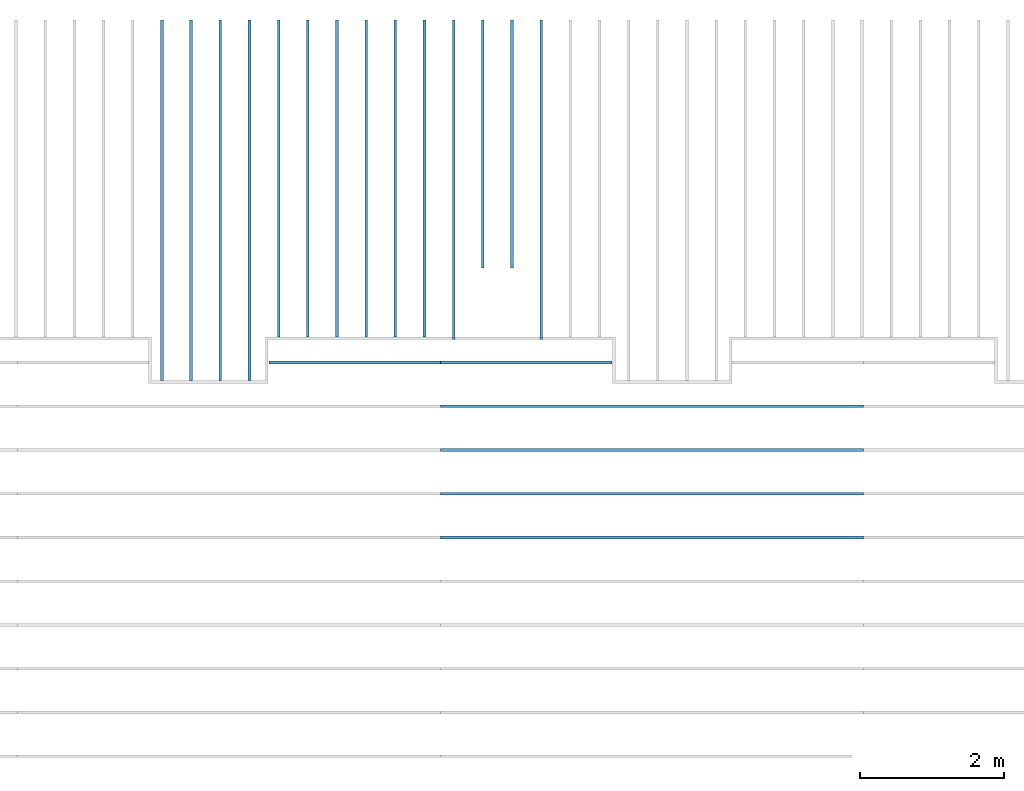
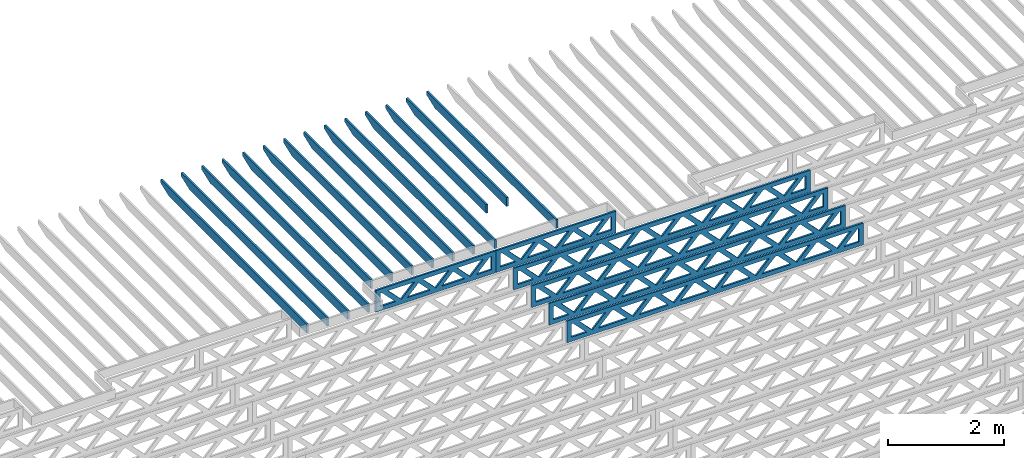
# One storey, part 9 of 18: 20 beams, 3 elements without a shape of their own.
"""IFC4 building model written with IfcOpenShell, lengths in feet."""

import ifcopenshell
import ifcopenshell.guid

model = None  # the IFC model being written
_history = None  # IfcOwnerHistory: only IFC2X3 demands one
_inside = {}  # id of a spatial element -> (the spatial element, [elements in it])
_under = {}  # id of a project, library or spatial element -> (it, [spatial elements below it])
_declared = {}  # id of a project -> (the project, [libraries it declares])
_typed = {}  # id of a type object -> (the type object, [elements of that type])
_made_of = {}  # id of a material, layer set ... -> (it, [elements and type objects made of it])


def new_model(schema):
    """Start an empty IFC model of exactly this schema.

    Asked for "IFC4X3", IfcOpenShell would pick the latest addendum, in which some entities
    have other attributes; the version numbers below select the first issue.
    IFC2X3 requires an IfcOwnerHistory on every rooted entity: one is made here for all.
    """
    global model, _history
    if schema == "IFC4X3":
        model = ifcopenshell.file(schema_version=(4, 3, 0, 0))
    else:
        model = ifcopenshell.file(schema=schema)
    _inside.clear()
    _under.clear()
    _declared.clear()
    _typed.clear()
    _made_of.clear()
    _history = None
    if model.schema == "IFC2X3":
        org = make("IfcOrganization", Name="unknown")
        user = make(
            "IfcPersonAndOrganization",
            ThePerson=make("IfcPerson", FamilyName="unknown"),
            TheOrganization=org,
        )
        app = make(
            "IfcApplication",
            ApplicationDeveloper=org,
            Version="unknown",
            ApplicationFullName="unknown",
            ApplicationIdentifier="unknown",
        )
        _history = make(
            "IfcOwnerHistory",
            OwningUser=user,
            OwningApplication=app,
            ChangeAction="ADDED",
            CreationDate=0,
        )
    return model


def make(cls, **values):
    """One entity of the class cls with the attributes given. An attribute that is None is left unset."""
    return model.create_entity(
        cls, **{name: value for name, value in values.items() if value is not None}
    )


def entity(cls, *values):
    """Any entity or typed value of the class cls, its attributes in the order of the schema. None: left unset."""
    e = model.create_entity(cls)
    for i, value in enumerate(values):
        if value is not None:
            e[i] = value
    return e


def rooted(cls, **values):
    """An entity with a GlobalId (a new one), such as an element, a storey or a relation."""
    return make(cls, GlobalId=ifcopenshell.guid.new(), OwnerHistory=_history, **values)


def si_unit(unit_type, name, prefix=None):
    """IfcSIUnit, for example si_unit("LENGTHUNIT", "METRE", prefix="MILLI")."""
    return make("IfcSIUnit", UnitType=unit_type, Prefix=prefix, Name=name)


def converted_unit(unit_type, name, factor, base, dimensions=None, offset=None):
    """IfcConversionBasedUnit, such as the inch: factor (a typed value) times the base unit."""
    return make(
        "IfcConversionBasedUnit"
        if offset is None
        else "IfcConversionBasedUnitWithOffset",
        ConversionOffset=offset,
        Dimensions=None
        if dimensions is None
        else entity("IfcDimensionalExponents", *dimensions),
        UnitType=unit_type,
        Name=name,
        ConversionFactor=make(
            "IfcMeasureWithUnit", ValueComponent=factor, UnitComponent=base
        ),
    )


def derived_unit(unit_type, elements):
    """IfcDerivedUnit: a product of units, each with its exponent."""
    return make(
        "IfcDerivedUnit",
        Elements=[
            make("IfcDerivedUnitElement", Unit=unit, Exponent=power)
            for unit, power in elements
        ],
        UnitType=unit_type,
    )


def assignment(units):
    """IfcUnitAssignment: the units of a project."""
    return None if units is None else make("IfcUnitAssignment", Units=units)


def point(xyz):
    """IfcCartesianPoint."""
    return None if xyz is None else make("IfcCartesianPoint", Coordinates=xyz)


def direction(xyz):
    """IfcDirection."""
    return None if xyz is None else make("IfcDirection", DirectionRatios=xyz)


def frame(location, z_axis=None, x_axis=None):
    """IfcAxis2Placement3D, a coordinate frame: its origin and axes. An axis left out is left unset."""
    return make(
        "IfcAxis2Placement3D",
        Location=point(location),
        Axis=direction(z_axis),
        RefDirection=direction(x_axis),
    )


def frame_2d(location, x_axis=None):
    """IfcAxis2Placement2D, a coordinate frame in the plane: its origin and x axis."""
    return make(
        "IfcAxis2Placement2D", Location=point(location), RefDirection=direction(x_axis)
    )


def origin():
    """The frame at (0, 0, 0) with its axes left unset."""
    return frame((0.0, 0.0, 0.0))


def origin_2d_with_axis():
    """The frame at (0, 0) in the plane with the x axis (1, 0) written out."""
    return frame_2d((0.0, 0.0), x_axis=(1.0, 0.0))


def place(relative_to, where):
    """IfcLocalPlacement: puts the frame where relative to a parent placement (None: the world)."""
    return make(
        "IfcLocalPlacement", PlacementRelTo=relative_to, RelativePlacement=where
    )


def context(
    kind, dimensions, precision=None, world=None, true_north=None, identifier=None
):
    """IfcGeometricRepresentationContext, for example the 3D "Model" context."""
    return make(
        "IfcGeometricRepresentationContext",
        ContextIdentifier=identifier,
        ContextType=kind,
        CoordinateSpaceDimension=dimensions,
        Precision=precision,
        WorldCoordinateSystem=world,
        TrueNorth=true_north,
    )


def subcontext(parent, identifier, kind, view, scale=None):
    """IfcGeometricRepresentationSubContext, for example "Body" below "Model"."""
    return make(
        "IfcGeometricRepresentationSubContext",
        ContextIdentifier=identifier,
        ContextType=kind,
        ParentContext=parent,
        TargetScale=scale,
        TargetView=view,
    )


def project(units=None, contexts=None):
    """IfcProject with its units and contexts."""
    return rooted(
        "IfcProject",
        Name="project",
        RepresentationContexts=contexts,
        UnitsInContext=assignment(units),
    )


def spatial(cls, under=None, at=None, **own):
    """A site, building, storey or space (cls), placed at a placement, below another one or the project."""
    s = rooted(cls, ObjectPlacement=at, **own)
    if under is not None:
        _under.setdefault(under.id(), (under, []))[1].append(s)
    return s


def profile(cls, at=None, kind="AREA", **sizes):
    """A parametric profile (cls). Its sizes go by their IFC names, for example OverallWidth=200.0."""
    return make(cls, ProfileType=kind, Position=at, **sizes)


def rectangle(**sizes):
    """IfcRectangleProfileDef."""
    return profile("IfcRectangleProfileDef", **sizes)


def extrude(swept, where, along, depth):
    """IfcExtrudedAreaSolid: the profile swept, set in the frame where, extruded along a direction by depth."""
    return make(
        "IfcExtrudedAreaSolid",
        SweptArea=swept,
        Position=where,
        ExtrudedDirection=direction(along),
        Depth=depth,
    )


def clip(a, b, op="DIFFERENCE"):
    """IfcBooleanClippingResult: the solid a cut by the half space b."""
    return make(
        "IfcBooleanClippingResult", Operator=op, FirstOperand=a, SecondOperand=b
    )


def halfspace(plane, agree):
    """IfcHalfSpaceSolid: all space on one side of the plane z = 0 of the frame plane."""
    return make(
        "IfcHalfSpaceSolid",
        BaseSurface=make("IfcPlane", Position=plane),
        AgreementFlag=agree,
    )


def shape(context_of_items, identifier, shape_type, items):
    """IfcShapeRepresentation: the items that make up one representation, for example the "Body"."""
    return make(
        "IfcShapeRepresentation",
        ContextOfItems=context_of_items,
        RepresentationIdentifier=identifier,
        RepresentationType=shape_type,
        Items=items,
    )


def source(mapping_origin, context_of_items, identifier, shape_type, items):
    """IfcRepresentationMap: a shape defined once, which mapped items show again and again."""
    return make(
        "IfcRepresentationMap",
        MappingOrigin=mapping_origin,
        MappedRepresentation=shape(context_of_items, identifier, shape_type, items),
    )


def transform(
    local_origin,
    x_axis=None,
    y_axis=None,
    z_axis=None,
    scale=None,
    scale2=None,
    scale3=None,
    uniform=True,
):
    """IfcCartesianTransformationOperator3D, or its non-uniform kind. x_axis, y_axis, z_axis: its Axis1, 2, 3."""
    if uniform:
        return make(
            "IfcCartesianTransformationOperator3D",
            Axis1=direction(x_axis),
            Axis2=direction(y_axis),
            LocalOrigin=point(local_origin),
            Scale=scale,
            Axis3=direction(z_axis),
        )
    return make(
        "IfcCartesianTransformationOperator3DnonUniform",
        Axis1=direction(x_axis),
        Axis2=direction(y_axis),
        LocalOrigin=point(local_origin),
        Scale=scale,
        Axis3=direction(z_axis),
        Scale2=scale2,
        Scale3=scale3,
    )


def mapped(mapping_source, mapping_target):
    """IfcMappedItem: shows the shape of a source again, moved by a transform."""
    return make(
        "IfcMappedItem", MappingSource=mapping_source, MappingTarget=mapping_target
    )


def material(Name=None, Category=None):
    """IfcMaterial."""
    return make("IfcMaterial", Name=Name, Category=Category)


def material_profile(
    of_material, cross_section, Name=None, Category=None, Priority=None
):
    """IfcMaterialProfile: a cross section and its material."""
    return make(
        "IfcMaterialProfile",
        Name=Name,
        Material=of_material,
        Profile=cross_section,
        Priority=Priority,
        Category=Category,
    )


def profile_set(profiles, Name=None, composite=None):
    """IfcMaterialProfileSet."""
    return make(
        "IfcMaterialProfileSet",
        Name=Name,
        MaterialProfiles=profiles,
        CompositeProfile=composite,
    )


def profile_usage(for_profile_set, cardinal=None, extent=None):
    """IfcMaterialProfileSetUsage: how a profile set lies along its element."""
    return make(
        "IfcMaterialProfileSetUsage",
        ForProfileSet=for_profile_set,
        CardinalPoint=cardinal,
        ReferenceExtent=extent,
    )


def made_of(thing, what):
    """Note that an element or type object is made of a material, layer set ...; save() writes the relation."""
    if what is not None:
        _made_of.setdefault(what.id(), (what, []))[1].append(thing)
    return thing


def type_object(cls, material=None, **own):
    """A type object (cls), such as IfcWallType, which elements share."""
    return made_of(rooted(cls, **own), material)


def type_shapes(of_type, sources):
    """Give a type object the sources (RepresentationMaps) that its elements show as mapped items."""
    of_type.RepresentationMaps = sources


def element(
    cls,
    number,
    at=None,
    inside=None,
    cuts=None,
    type_object=None,
    material=None,
    context=None,
    identifier="Body",
    shape_type=None,
    held_by="IfcProductDefinitionShape",
    body=None,
    shapes=None,
    **own,
):
    """One element of the class cls, such as IfcWall. Its Tag is "e" and its number.

    at: its placement. inside: the storey or other place that contains it. cuts: it is an
    opening in that element (IfcRelVoidsElement). A single representation is given by context,
    identifier, shape_type and body (its items); several are given by shapes. held_by: the class
    of the entity that holds the representations. save() writes the other relations.
    """
    e = rooted(cls, Tag="e%d" % number, ObjectPlacement=at, **own)
    if body is not None:
        shapes = [shape(context, identifier, shape_type, body)]
    if shapes is not None:
        e.Representation = make(held_by, Representations=shapes)
    if inside is not None:
        _inside.setdefault(inside.id(), (inside, []))[1].append(e)
    if cuts is not None:
        rooted(
            "IfcRelVoidsElement", RelatingBuildingElement=cuts, RelatedOpeningElement=e
        )
    if type_object is not None:
        _typed.setdefault(type_object.id(), (type_object, []))[1].append(e)
    return made_of(e, material)


def aggregate(whole, parts):
    """IfcRelAggregates: a whole, such as a stair, and the parts it consists of."""
    return rooted("IfcRelAggregates", RelatingObject=whole, RelatedObjects=parts)


def save(model, path):
    """Write the relations noted so far, then the file.

    IfcRelAggregates (storeys below a building ...), IfcRelContainedInSpatialStructure (elements
    in a storey), IfcRelDefinesByType, IfcRelAssociatesMaterial and IfcRelDeclares: one each for
    every whole, place, type object, material and project.
    """
    for whole, parts in _under.values():
        aggregate(whole, parts)
    for where, things in _inside.values():
        rooted(
            "IfcRelContainedInSpatialStructure",
            RelatedElements=things,
            RelatingStructure=where,
        )
    for kind, things in _typed.values():
        rooted("IfcRelDefinesByType", RelatedObjects=things, RelatingType=kind)
    for what, things in _made_of.values():
        rooted("IfcRelAssociatesMaterial", RelatedObjects=things, RelatingMaterial=what)
    for by, libraries in _declared.values():
        rooted("IfcRelDeclares", RelatingContext=by, RelatedDefinitions=libraries)
    model.write(path)


model = new_model("IFC4")

# Units and contexts
model_context_1 = context("Model", 3, precision=0.0001, world=origin(), true_north=direction((6.12303176911189e-17, 1.0)))
model_context_2 = context("Model", 3, precision=0.0001, world=origin(), true_north=direction((6.12303176911189e-17, 1.0)))
body_context = subcontext(model_context_2, "Body", "Model", "MODEL_VIEW")
ifc_project = project(units=[converted_unit("LENGTHUNIT", "FOOT", entity("IfcRatioMeasure", 0.3048), si_unit("LENGTHUNIT", "METRE"), dimensions=[1, 0, 0, 0, 0, 0, 0]), converted_unit("AREAUNIT", "SQUARE FOOT", entity("IfcRatioMeasure", 0.09290304), si_unit("AREAUNIT", "SQUARE_METRE"), dimensions=[2, 0, 0, 0, 0, 0, 0]), converted_unit("VOLUMEUNIT", "CUBIC FOOT", entity("IfcRatioMeasure", 0.028316846592), si_unit("VOLUMEUNIT", "CUBIC_METRE"), dimensions=[3, 0, 0, 0, 0, 0, 0]), converted_unit("PLANEANGLEUNIT", "DEGREE", entity("IfcRatioMeasure", 0.0174532925199433), si_unit("PLANEANGLEUNIT", "RADIAN"), dimensions=[0, 0, 0, 0, 0, 0, 0]), si_unit("MASSUNIT", "GRAM", prefix="KILO"), derived_unit("MASSDENSITYUNIT", [(si_unit("MASSUNIT", "GRAM", prefix="KILO"), 1), (si_unit("LENGTHUNIT", "METRE"), -3)]), derived_unit("MOMENTOFINERTIAUNIT", [(si_unit("LENGTHUNIT", "METRE"), 4)]), si_unit("TIMEUNIT", "SECOND"), si_unit("FREQUENCYUNIT", "HERTZ"), si_unit("THERMODYNAMICTEMPERATUREUNIT", "DEGREE_CELSIUS"), derived_unit("THERMALTRANSMITTANCEUNIT", [(si_unit("MASSUNIT", "GRAM", prefix="KILO"), 1), (si_unit("THERMODYNAMICTEMPERATUREUNIT", "KELVIN"), -1), (si_unit("TIMEUNIT", "SECOND"), -3)]), derived_unit("VOLUMETRICFLOWRATEUNIT", [(si_unit("LENGTHUNIT", "METRE"), 3), (si_unit("TIMEUNIT", "SECOND"), -1)]), si_unit("ELECTRICCURRENTUNIT", "AMPERE"), si_unit("ELECTRICVOLTAGEUNIT", "VOLT"), si_unit("POWERUNIT", "WATT"), si_unit("FORCEUNIT", "NEWTON"), si_unit("ILLUMINANCEUNIT", "LUX"), si_unit("LUMINOUSFLUXUNIT", "LUMEN"), si_unit("LUMINOUSINTENSITYUNIT", "CANDELA"), derived_unit("USERDEFINED", [(si_unit("MASSUNIT", "GRAM", prefix="KILO"), -1), (si_unit("LENGTHUNIT", "METRE"), -2), (si_unit("TIMEUNIT", "SECOND"), 3), (si_unit("LUMINOUSFLUXUNIT", "LUMEN"), 1)]), derived_unit("LINEARVELOCITYUNIT", [(si_unit("LENGTHUNIT", "METRE"), 1), (si_unit("TIMEUNIT", "SECOND"), -1)]), si_unit("PRESSUREUNIT", "PASCAL"), derived_unit("USERDEFINED", [(si_unit("LENGTHUNIT", "METRE"), -2), (si_unit("MASSUNIT", "GRAM", prefix="KILO"), 1), (si_unit("TIMEUNIT", "SECOND"), -2)]), derived_unit("LINEARFORCEUNIT", [(si_unit("MASSUNIT", "GRAM", prefix="KILO"), 1), (si_unit("LENGTHUNIT", "METRE"), 1), (si_unit("TIMEUNIT", "SECOND"), -2), (si_unit("LENGTHUNIT", "METRE"), -1)]), derived_unit("PLANARFORCEUNIT", [(si_unit("MASSUNIT", "GRAM", prefix="KILO"), 1), (si_unit("LENGTHUNIT", "METRE"), 1), (si_unit("TIMEUNIT", "SECOND"), -2), (si_unit("LENGTHUNIT", "METRE"), -2)])], contexts=[model_context_1])

# Site, building, storey
site_placement = place(None, origin())
site = spatial("IfcSite", under=ifc_project, at=site_placement, CompositionType="ELEMENT")
building_placement = place(site_placement, origin())
building = spatial("IfcBuilding", under=site, at=building_placement, CompositionType="ELEMENT")
storey_placement = place(building_placement, frame((0.0, 0.0, 30.4375000000082)))
storey = spatial("IfcBuildingStorey", under=building, at=storey_placement, Name="ROOF", CompositionType="ELEMENT", Elevation=30.4375000000082)

# Assembly, beam
assembly_1_placement = place(storey_placement, origin())
assembly_1 = element("IfcElementAssembly", 1, at=assembly_1_placement, inside=storey, Name="Structural Beam System:Structural Framing System", ObjectType="Structural Beam System:Structural Framing System", AssemblyPlace="NOTDEFINED", PredefinedType="BEAM_GRID")
ifc_material_1 = material(Name="WOOD TRUSS", Category="Materials")
ifc_material_profile_1 = material_profile(ifc_material_1, rectangle(XDim=1.73473973950632, YDim=0.125, at=origin_2d_with_axis()))
ifc_material_profile_2 = material_profile(ifc_material_1, rectangle(XDim=1.73473973950633, YDim=0.125, at=frame_2d((-1.11022302462516e-16, 0.0), x_axis=(1.0, 0.0))))
ifc_material_profile_3 = material_profile(ifc_material_1, rectangle(XDim=1.73473973950632, YDim=0.125, at=origin_2d_with_axis()))
ifc_material_profile_4 = material_profile(ifc_material_1, rectangle(XDim=1.73473973950633, YDim=0.125, at=origin_2d_with_axis()))
ifc_material_profile_5 = material_profile(ifc_material_1, rectangle(XDim=1.73473973950632, YDim=0.125, at=frame_2d((-5.55111512312578e-17, 0.0), x_axis=(1.0, 0.0))))
ifc_material_profile_6 = material_profile(ifc_material_1, rectangle(XDim=1.73473973950633, YDim=0.125, at=frame_2d((-2.77555756156289e-16, 0.0), x_axis=(1.0, 0.0))))
ifc_material_profile_7 = material_profile(ifc_material_1, rectangle(XDim=1.73473973950632, YDim=0.125, at=frame_2d((-4.9960036108132e-16, 0.0), x_axis=(1.0, 0.0))))
ifc_material_profile_8 = material_profile(ifc_material_1, rectangle(XDim=1.73473973950633, YDim=0.125, at=frame_2d((4.44089209850063e-16, 0.0), x_axis=(1.0, 0.0))))
ifc_material_profile_9 = material_profile(ifc_material_1, rectangle(XDim=1.73473973950632, YDim=0.125, at=origin_2d_with_axis()))
ifc_material_profile_10 = material_profile(ifc_material_1, rectangle(XDim=1.73473973950633, YDim=0.125, at=frame_2d((-4.9960036108132e-16, 0.0), x_axis=(1.0, 0.0))))
ifc_material_profile_11 = material_profile(ifc_material_1, rectangle(XDim=0.291666666666664, YDim=0.125, at=frame_2d((-2.77555756156289e-17, 0.0), x_axis=(1.0, 0.0))))
ifc_material_profile_12 = material_profile(ifc_material_1, rectangle(XDim=0.291666666666628, YDim=0.124999999999995, at=frame_2d((-5.55111512312578e-17, 0.0), x_axis=(1.0, 0.0))))
ifc_material_profile_13 = material_profile(ifc_material_1, rectangle(XDim=0.916666666666666, YDim=0.125000000000003, at=frame_2d((-2.77555756156289e-17, 0.0), x_axis=(1.0, 0.0))))
ifc_material_profile_14 = material_profile(ifc_material_1, rectangle(XDim=0.916666666666651, YDim=0.125, at=frame_2d((-2.77555756156289e-17, 0.0), x_axis=(1.0, 0.0))))
ifc_profile_set_1 = profile_set([ifc_material_profile_1, ifc_material_profile_2, ifc_material_profile_3, ifc_material_profile_4, ifc_material_profile_5, ifc_material_profile_6, ifc_material_profile_7, ifc_material_profile_8, ifc_material_profile_9, ifc_material_profile_10, ifc_material_profile_11, ifc_material_profile_12, ifc_material_profile_13, ifc_material_profile_14])
ifc_profile_usage_1 = profile_usage(ifc_profile_set_1, cardinal=8)
beam_type_1 = type_object("IfcBeamType", PredefinedType="BEAM", material=ifc_profile_set_1)
shared_shape_1 = source(origin(), body_context, "Body", "SweptSolid", [
    extrude(rectangle(XDim=1.73473973950632, YDim=0.125, at=origin_2d_with_axis()), frame((0.520059930714935, 0.0, 0.101118361020562), z_axis=(0.720569184836762, 0.0, -0.693383046997606), x_axis=(0.693383046997606, 0.0, 0.720569184836762)), (0.0, 0.0, 1.0), 0.291666666666667),
    extrude(rectangle(XDim=1.73473973950633, YDim=0.125, at=origin_2d_with_axis()), frame((-0.730225942958335, 0.0, -0.101118361020407), z_axis=(0.720569184836758, 0.0, 0.69338304699761), x_axis=(0.69338304699761, 0.0, -0.720569184836758)), (0.0, 0.0, 1.0), 0.291666666666666),
    extrude(rectangle(XDim=1.73473973950632, YDim=0.125, at=origin_2d_with_axis()), frame((2.77005984700217, 0.0, 0.101118361020514), z_axis=(0.720569184836762, 0.0, -0.693383046997606), x_axis=(0.693383046997606, 0.0, 0.720569184836762)), (0.0, 0.0, 1.0), 0.291666666666667),
    extrude(rectangle(XDim=1.73473973950633, YDim=0.125, at=frame_2d((-1.11022302462516e-16, 0.0), x_axis=(1.0, 0.0))), frame((1.5197739733289, 0.0, -0.101118361020455), z_axis=(0.720569184836758, 0.0, 0.69338304699761), x_axis=(0.69338304699761, 0.0, -0.720569184836758)), (0.0, 0.0, 1.0), 0.291666666666666),
    extrude(rectangle(XDim=1.73473973950632, YDim=0.125, at=frame_2d((-5.55111512312578e-17, 0.0), x_axis=(1.0, 0.0))), frame((-1.7299399855723, 0.0, 0.101118361020555), z_axis=(0.720569184836762, 0.0, -0.693383046997606), x_axis=(0.693383046997606, 0.0, 0.720569184836762)), (0.0, 0.0, 1.0), 0.291666666666667),
    extrude(rectangle(XDim=1.73473973950633, YDim=0.125, at=frame_2d((-2.77555756156289e-16, 0.0), x_axis=(1.0, 0.0))), frame((-2.98022585924557, 0.0, -0.101118361020414), z_axis=(0.720569184836758, 0.0, 0.69338304699761), x_axis=(0.69338304699761, 0.0, -0.720569184836758)), (0.0, 0.0, 1.0), 0.291666666666666),
    extrude(rectangle(XDim=0.291666666666664, YDim=0.125, at=frame_2d((-2.77555756156289e-17, 0.0), x_axis=(1.0, 0.0))), frame((-3.91666658295382, 0.0, 0.604166666666611), z_axis=(1.0, 0.0, 0.0), x_axis=(0.0, 0.0, -1.0)), (0.0, 0.0, 1.0), 7.83333316590765),
    extrude(rectangle(XDim=0.291666666666628, YDim=0.124999999999995, at=frame_2d((-5.55111512312578e-17, 0.0), x_axis=(1.0, 0.0))), frame((-3.91666658295361, 0.0, -0.604166666666693), z_axis=(1.0, 0.0, 0.0), x_axis=(0.0, 0.0, -1.0)), (0.0, 0.0, 1.0), 7.83333316590743),
    extrude(rectangle(XDim=0.916666666666666, YDim=0.125000000000003, at=frame_2d((-2.77555756156289e-17, 0.0), x_axis=(1.0, 0.0))), frame((3.62499991628714, 0.0, 0.0), z_axis=(1.0, 0.0, 0.0), x_axis=(0.0, 0.0, -1.0)), (0.0, 0.0, 1.0), 0.291666666666687),
    extrude(rectangle(XDim=0.916666666666651, YDim=0.125, at=frame_2d((-2.77555756156289e-17, 0.0), x_axis=(1.0, 0.0))), frame((-3.91666658295382, 0.0, 0.0), z_axis=(1.0, 0.0, 0.0), x_axis=(0.0, 0.0, -1.0)), (0.0, 0.0, 1.0), 0.291666666666687),
])
type_shapes(beam_type_1, [shared_shape_1])
beam_1_placement = place(assembly_1_placement, frame((-199.154827235941, 957.861934882651, 0.749999999991587)))
beam_1 = element("IfcBeam", 2, at=beam_1_placement, type_object=beam_type_1, material=ifc_profile_usage_1, PredefinedType="BEAM", context=body_context, shape_type="MappedRepresentation", body=[
    mapped(shared_shape_1, transform((0.0, 0.0, 0.0), scale=1.0)),
])

assembly_2_placement = place(storey_placement, origin())
assembly_2 = element("IfcElementAssembly", 3, at=assembly_2_placement, inside=storey, Name="Structural Beam System:Structural Framing System", ObjectType="Structural Beam System:Structural Framing System", AssemblyPlace="NOTDEFINED", PredefinedType="BEAM_GRID")
ifc_profile_usage_2 = profile_usage(ifc_profile_set_1, cardinal=8)
beam_2_placement = place(assembly_2_placement, frame((-206.988160401782, 957.861934882651, 0.749999999991587), z_axis=(0.0, 0.0, 1.0), x_axis=(-1.0, 0.0, 0.0)))
beam_2 = element("IfcBeam", 4, at=beam_2_placement, type_object=beam_type_1, material=ifc_profile_usage_2, PredefinedType="BEAM", context=body_context, shape_type="MappedRepresentation", body=[
    mapped(shared_shape_1, transform((0.0, 0.0, 0.0), scale=1.0)),
])
aggregate(assembly_2, [beam_2])

# Assembly, beams
assembly_3_placement = place(storey_placement, origin())
assembly_3 = element("IfcElementAssembly", 5, at=assembly_3_placement, inside=storey, Name="Structural Beam System:Structural Framing System", ObjectType="Structural Beam System:Structural Framing System", AssemblyPlace="NOTDEFINED", PredefinedType="BEAM_GRID")
ifc_material_2 = material(Name="2X ROOF JOISTS - EXT. STAIN-1 - SEE LIFE SAFETY", Category="Materials")
ifc_material_profile_15 = material_profile(ifc_material_2, rectangle(XDim=0.604166666666667, YDim=0.125000000000011, at=frame_2d((0.0, 0.0), x_axis=(0.0, 1.0))))
ifc_profile_set_2 = profile_set([ifc_material_profile_15])
ifc_profile_usage_3 = profile_usage(ifc_profile_set_2, cardinal=8)
beam_type_2 = type_object("IfcBeamType", PredefinedType="BEAM", material=ifc_profile_set_2)
shared_shape_2 = source(origin(), body_context, "Body", "Clipping", [
    clip(extrude(rectangle(XDim=0.604166666666667, YDim=0.125000000000011, at=frame_2d((0.0, 0.0), x_axis=(0.0, 1.0))), frame((-8.24296473987818, 0.0, 0.0), z_axis=(1.0, 0.0, 0.0), x_axis=(0.0, 1.0, 0.0)), (0.0, 0.0, 1.0), 16.4859294797564), halfspace(frame((-7.26989982048795, -0.0625000000000026, -0.30208333333334), z_axis=(-0.34202014332567, 0.0, -0.939692620785908), x_axis=(0.0, 1.0, 0.0)), False)),
])
type_shapes(beam_type_2, [shared_shape_2])
beam_3_placement = place(assembly_3_placement, frame((-215.800660485462, 965.271566289195, 1.07291666665832), z_axis=(0.0, 0.0, 1.0), x_axis=(0.0, -1.0, 0.0)))
beam_3 = element("IfcBeam", 6, at=beam_3_placement, type_object=beam_type_2, material=ifc_profile_usage_3, PredefinedType="BEAM", context=body_context, shape_type="MappedRepresentation", body=[
    mapped(shared_shape_2, transform((0.0, 0.0, 0.0), scale=1.0)),
])
ifc_profile_usage_4 = profile_usage(ifc_profile_set_2, cardinal=8)
beam_4_placement = place(assembly_3_placement, frame((-211.800660485462, 965.271566289195, 1.07291666665832), z_axis=(0.0, 0.0, 1.0), x_axis=(0.0, -1.0, 0.0)))
beam_4 = element("IfcBeam", 7, at=beam_4_placement, type_object=beam_type_2, material=ifc_profile_usage_4, PredefinedType="BEAM", context=body_context, shape_type="MappedRepresentation", body=[
    mapped(shared_shape_2, transform((0.0, 0.0, 0.0), scale=1.0)),
])
ifc_profile_usage_5 = profile_usage(ifc_profile_set_2, cardinal=8)
beam_5_placement = place(assembly_3_placement, frame((-213.133993818795, 965.271566289195, 1.07291666665832), z_axis=(0.0, 0.0, 1.0), x_axis=(0.0, -1.0, 0.0)))
beam_5 = element("IfcBeam", 8, at=beam_5_placement, type_object=beam_type_2, material=ifc_profile_usage_5, PredefinedType="BEAM", context=body_context, shape_type="MappedRepresentation", body=[
    mapped(shared_shape_2, transform((0.0, 0.0, 0.0), scale=1.0)),
])
ifc_profile_usage_6 = profile_usage(ifc_profile_set_2, cardinal=8)
beam_6_placement = place(assembly_3_placement, frame((-214.467327152128, 965.271566289195, 1.07291666665832), z_axis=(0.0, 0.0, 1.0), x_axis=(0.0, -1.0, 0.0)))
beam_6 = element("IfcBeam", 9, at=beam_6_placement, type_object=beam_type_2, material=ifc_profile_usage_6, PredefinedType="BEAM", context=body_context, shape_type="MappedRepresentation", body=[
    mapped(shared_shape_2, transform((0.0, 0.0, 0.0), scale=1.0)),
])
ifc_profile_usage_7 = profile_usage(ifc_profile_set_2, cardinal=8)
beam_type_3 = type_object("IfcBeamType", PredefinedType="BEAM", material=ifc_profile_set_2)
shared_shape_3 = source(origin(), body_context, "Body", "Clipping", [
    clip(extrude(rectangle(XDim=0.604166666666667, YDim=0.125000000000011, at=frame_2d((0.0, 0.0), x_axis=(0.0, 1.0))), frame((-7.24296367016814, 0.0, 0.0), z_axis=(1.0, 0.0, 0.0), x_axis=(0.0, 1.0, 0.0)), (0.0, 0.0, 1.0), 14.4859273403363), halfspace(frame((-6.26989875077791, -0.0625000000000026, -0.30208333333334), z_axis=(-0.34202014332567, 0.0, -0.939692620785908), x_axis=(0.0, 1.0, 0.0)), False)),
])
type_shapes(beam_type_3, [shared_shape_3])
beam_7_placement = place(assembly_3_placement, frame((-206.467327152128, 966.271567358905, 1.07291666665831), z_axis=(0.0, 0.0, 1.0), x_axis=(0.0, -1.0, 0.0)))
beam_7 = element("IfcBeam", 10, at=beam_7_placement, type_object=beam_type_3, material=ifc_profile_usage_7, PredefinedType="BEAM", context=body_context, shape_type="MappedRepresentation", body=[
    mapped(shared_shape_3, transform((0.0, 0.0, 0.0), scale=1.0)),
])
ifc_profile_usage_8 = profile_usage(ifc_profile_set_2, cardinal=8)
beam_type_4 = type_object("IfcBeamType", PredefinedType="BEAM", material=ifc_profile_set_2)
shared_shape_4 = source(origin(), body_context, "Body", "Clipping", [
    clip(extrude(rectangle(XDim=0.604166666666667, YDim=0.125000000000011, at=frame_2d((0.0, 0.0), x_axis=(0.0, 1.0))), frame((-7.24296336754674, 0.0, 0.0), z_axis=(1.0, 0.0, 0.0), x_axis=(0.0, 1.0, 0.0)), (0.0, 0.0, 1.0), 14.4859267350935), halfspace(frame((-6.26989844815651, -0.0625000000000026, -0.30208333333334), z_axis=(-0.34202014332567, 0.0, -0.939692620785908), x_axis=(0.0, 1.0, 0.0)), False)),
])
type_shapes(beam_type_4, [shared_shape_4])
beam_8_placement = place(assembly_3_placement, frame((-209.133993818795, 966.271567661527, 1.07291666665832), z_axis=(0.0, 0.0, 1.0), x_axis=(0.0, -1.0, 0.0)))
beam_8 = element("IfcBeam", 11, at=beam_8_placement, type_object=beam_type_4, material=ifc_profile_usage_8, PredefinedType="BEAM", context=body_context, shape_type="MappedRepresentation", body=[
    mapped(shared_shape_4, transform((0.0, 0.0, 0.0), scale=1.0)),
])
ifc_profile_usage_9 = profile_usage(ifc_profile_set_2, cardinal=8)
beam_type_5 = type_object("IfcBeamType", PredefinedType="BEAM", material=ifc_profile_set_2)
shared_shape_5 = source(origin(), body_context, "Body", "Clipping", [
    clip(extrude(rectangle(XDim=0.604166666666667, YDim=0.125000000000011, at=frame_2d((0.0, -1.11022302462516e-16), x_axis=(0.0, 1.0))), frame((-7.2429638214789, 0.0, 0.0), z_axis=(1.0, 0.0, 0.0), x_axis=(0.0, 1.0, 0.0)), (0.0, 0.0, 1.0), 14.4859276429578), halfspace(frame((-6.26989890208867, -0.0625000000000026, -0.30208333333334), z_axis=(-0.34202014332567, 0.0, -0.939692620785908), x_axis=(0.0, 1.0, 0.0)), False)),
])
type_shapes(beam_type_5, [shared_shape_5])
beam_9_placement = place(assembly_3_placement, frame((-205.133993818795, 966.271567207594, 1.07291666665831), z_axis=(0.0, 0.0, 1.0), x_axis=(0.0, -1.0, 0.0)))
beam_9 = element("IfcBeam", 12, at=beam_9_placement, type_object=beam_type_5, material=ifc_profile_usage_9, PredefinedType="BEAM", context=body_context, shape_type="MappedRepresentation", body=[
    mapped(shared_shape_5, transform((0.0, 0.0, 0.0), scale=1.0)),
])
ifc_profile_usage_10 = profile_usage(ifc_profile_set_2, cardinal=8)
beam_type_6 = type_object("IfcBeamType", PredefinedType="BEAM", material=ifc_profile_set_2)
shared_shape_6 = source(origin(), body_context, "Body", "Clipping", [
    clip(extrude(rectangle(XDim=0.604166666666667, YDim=0.125000000000011, at=frame_2d((0.0, 0.0), x_axis=(0.0, 1.0))), frame((-5.78805380202516, 0.0, 0.0), z_axis=(1.0, 0.0, 0.0), x_axis=(0.0, 1.0, 0.0)), (0.0, 0.0, 1.0), 11.3399841963574), halfspace(frame((-4.81498888263493, -0.0625000000000026, -0.30208333333334), z_axis=(-0.34202014332567, 0.0, -0.939692620785908), x_axis=(0.0, 1.0, 0.0)), False)),
])
type_shapes(beam_type_6, [shared_shape_6])
beam_10_placement = place(assembly_3_placement, frame((-199.800660485462, 967.726477227048, 1.0729166666583), z_axis=(0.0, 0.0, 1.0), x_axis=(0.0, -1.0, 0.0)))
beam_10 = element("IfcBeam", 13, at=beam_10_placement, type_object=beam_type_6, material=ifc_profile_usage_10, PredefinedType="BEAM", context=body_context, shape_type="MappedRepresentation", body=[
    mapped(shared_shape_6, transform((0.0, 0.0, 0.0), scale=1.0)),
])
ifc_profile_usage_11 = profile_usage(ifc_profile_set_2, cardinal=8)
beam_11_placement = place(assembly_3_placement, frame((-201.133993818795, 967.726477227048, 1.07291666665831), z_axis=(0.0, 0.0, 1.0), x_axis=(0.0, -1.0, 0.0)))
beam_11 = element("IfcBeam", 14, at=beam_11_placement, type_object=beam_type_6, material=ifc_profile_usage_11, PredefinedType="BEAM", context=body_context, shape_type="MappedRepresentation", body=[
    mapped(shared_shape_6, transform((0.0, 0.0, 0.0), scale=1.0)),
])
ifc_profile_usage_12 = profile_usage(ifc_profile_set_2, cardinal=8)
beam_type_7 = type_object("IfcBeamType", PredefinedType="BEAM", material=ifc_profile_set_2)
shared_shape_7 = source(origin(), body_context, "Body", "Clipping", [
    clip(extrude(rectangle(XDim=0.604166666666667, YDim=0.125000000000011, at=frame_2d((0.0, -1.11022302462516e-16), x_axis=(0.0, 1.0))), frame((-7.24296467719904, 0.0, 0.0), z_axis=(1.0, 0.0, 0.0), x_axis=(0.0, 1.0, 0.0)), (0.0, 0.0, 1.0), 14.6109291868968), halfspace(frame((-6.26989975780881, -0.0625000000000026, -0.30208333333334), z_axis=(-0.34202014332567, 0.0, -0.939692620785908), x_axis=(0.0, 1.0, 0.0)), False)),
])
type_shapes(beam_type_7, [shared_shape_7])
beam_12_placement = place(assembly_3_placement, frame((-198.467327152128, 966.271566351874, 1.07291666665831), z_axis=(0.0, 0.0, 1.0), x_axis=(0.0, -1.0, 0.0)))
beam_12 = element("IfcBeam", 15, at=beam_12_placement, type_object=beam_type_7, material=ifc_profile_usage_12, PredefinedType="BEAM", context=body_context, shape_type="MappedRepresentation", body=[
    mapped(shared_shape_7, transform((0.0, 0.0, 0.0), scale=1.0)),
])
ifc_profile_usage_13 = profile_usage(ifc_profile_set_2, cardinal=8)
beam_type_8 = type_object("IfcBeamType", PredefinedType="BEAM", material=ifc_profile_set_2)
shared_shape_8 = source(origin(), body_context, "Body", "Clipping", [
    clip(extrude(rectangle(XDim=0.604166666666667, YDim=0.125000000000011, at=frame_2d((0.0, -1.11022302462516e-16), x_axis=(0.0, 1.0))), frame((-7.2429641241003, 0.0, 0.0), z_axis=(1.0, 0.0, 0.0), x_axis=(0.0, 1.0, 0.0)), (0.0, 0.0, 1.0), 14.6109291868968), halfspace(frame((-6.26989920471007, -0.0625000000000026, -0.30208333333334), z_axis=(-0.34202014332567, 0.0, -0.939692620785908), x_axis=(0.0, 1.0, 0.0)), False)),
])
type_shapes(beam_type_8, [shared_shape_8])
beam_13_placement = place(assembly_3_placement, frame((-202.467327152128, 966.271566904973, 1.07291666665831), z_axis=(0.0, 0.0, 1.0), x_axis=(0.0, -1.0, 0.0)))
beam_13 = element("IfcBeam", 16, at=beam_13_placement, type_object=beam_type_8, material=ifc_profile_usage_13, PredefinedType="BEAM", context=body_context, shape_type="MappedRepresentation", body=[
    mapped(shared_shape_8, transform((0.0, 0.0, 0.0), scale=1.0)),
])
ifc_profile_usage_14 = profile_usage(ifc_profile_set_2, cardinal=8)
beam_type_9 = type_object("IfcBeamType", PredefinedType="BEAM", material=ifc_profile_set_2)
shared_shape_9 = source(origin(), body_context, "Body", "Clipping", [
    clip(extrude(rectangle(XDim=0.604166666666667, YDim=0.125000000000011, at=frame_2d((0.0, 0.0), x_axis=(0.0, 1.0))), frame((-7.2429639727896, 0.0, 0.0), z_axis=(1.0, 0.0, 0.0), x_axis=(0.0, 1.0, 0.0)), (0.0, 0.0, 1.0), 14.4859279455792), halfspace(frame((-6.26989905339937, -0.0625000000000026, -0.30208333333334), z_axis=(-0.34202014332567, 0.0, -0.939692620785908), x_axis=(0.0, 1.0, 0.0)), False)),
])
type_shapes(beam_type_9, [shared_shape_9])
beam_14_placement = place(assembly_3_placement, frame((-203.800660485462, 966.271567056284, 1.07291666665831), z_axis=(0.0, 0.0, 1.0), x_axis=(0.0, -1.0, 0.0)))
beam_14 = element("IfcBeam", 17, at=beam_14_placement, type_object=beam_type_9, material=ifc_profile_usage_14, PredefinedType="BEAM", context=body_context, shape_type="MappedRepresentation", body=[
    mapped(shared_shape_9, transform((0.0, 0.0, 0.0), scale=1.0)),
])
ifc_profile_usage_15 = profile_usage(ifc_profile_set_2, cardinal=8)
beam_type_10 = type_object("IfcBeamType", PredefinedType="BEAM", material=ifc_profile_set_2)
shared_shape_10 = source(origin(), body_context, "Body", "Clipping", [
    clip(extrude(rectangle(XDim=0.604166666666667, YDim=0.125000000000011, at=frame_2d((0.0, 0.0), x_axis=(0.0, 1.0))), frame((-7.24296351885744, 0.0, 0.0), z_axis=(1.0, 0.0, 0.0), x_axis=(0.0, 1.0, 0.0)), (0.0, 0.0, 1.0), 14.4859270377149), halfspace(frame((-6.26989859946721, -0.0625000000000026, -0.30208333333334), z_axis=(-0.34202014332567, 0.0, -0.939692620785908), x_axis=(0.0, 1.0, 0.0)), False)),
])
type_shapes(beam_type_10, [shared_shape_10])
beam_15_placement = place(assembly_3_placement, frame((-207.800660485462, 966.271567510216, 1.07291666665832), z_axis=(0.0, 0.0, 1.0), x_axis=(0.0, -1.0, 0.0)))
beam_15 = element("IfcBeam", 18, at=beam_15_placement, type_object=beam_type_10, material=ifc_profile_usage_15, PredefinedType="BEAM", context=body_context, shape_type="MappedRepresentation", body=[
    mapped(shared_shape_10, transform((0.0, 0.0, 0.0), scale=1.0)),
])
ifc_profile_usage_16 = profile_usage(ifc_profile_set_2, cardinal=8)
beam_type_11 = type_object("IfcBeamType", PredefinedType="BEAM", material=ifc_profile_set_2)
shared_shape_11 = source(origin(), body_context, "Body", "Clipping", [
    clip(extrude(rectangle(XDim=0.604166666666667, YDim=0.125000000000011, at=frame_2d((0.0, 0.0), x_axis=(0.0, 1.0))), frame((-7.24296321623603, 0.0, 0.0), z_axis=(1.0, 0.0, 0.0), x_axis=(0.0, 1.0, 0.0)), (0.0, 0.0, 1.0), 14.4859264324721), halfspace(frame((-6.26989829684581, -0.0625000000000026, -0.30208333333334), z_axis=(-0.34202014332567, 0.0, -0.939692620785908), x_axis=(0.0, 1.0, 0.0)), False)),
])
type_shapes(beam_type_11, [shared_shape_11])
beam_16_placement = place(assembly_3_placement, frame((-210.467327152128, 966.271567812837, 1.07291666665832), z_axis=(0.0, 0.0, 1.0), x_axis=(0.0, -1.0, 0.0)))
beam_16 = element("IfcBeam", 19, at=beam_16_placement, type_object=beam_type_11, material=ifc_profile_usage_16, PredefinedType="BEAM", context=body_context, shape_type="MappedRepresentation", body=[
    mapped(shared_shape_11, transform((0.0, 0.0, 0.0), scale=1.0)),
])
aggregate(assembly_3, [beam_3, beam_8, beam_9, beam_10, beam_12, beam_11, beam_13, beam_14, beam_7, beam_15, beam_16, beam_4, beam_5, beam_6])

# Beam
ifc_profile_usage_17 = profile_usage(ifc_profile_set_1, cardinal=8)
beam_type_12 = type_object("IfcBeamType", PredefinedType="BEAM", material=ifc_profile_set_1)
shared_shape_12 = source(origin(), body_context, "Body", "SweptSolid", [
    extrude(rectangle(XDim=1.73473973950632, YDim=0.125, at=frame_2d((-5.55111512312578e-16, 0.0), x_axis=(1.0, 0.0))), frame((5.85339326404794, 0.0, 0.101118361020562), z_axis=(0.720569184836762, 0.0, -0.693383046997606), x_axis=(0.693383046997606, 0.0, 0.720569184836762)), (0.0, 0.0, 1.0), 0.291666666666667),
    extrude(rectangle(XDim=1.73473973950633, YDim=0.125, at=frame_2d((-4.9960036108132e-16, 0.0), x_axis=(1.0, 0.0))), frame((4.60310739037467, 0.0, -0.101118361020407), z_axis=(0.720569184836758, 0.0, 0.69338304699761), x_axis=(0.69338304699761, 0.0, -0.720569184836758)), (0.0, 0.0, 1.0), 0.291666666666667),
    extrude(rectangle(XDim=1.73473973950632, YDim=0.125, at=frame_2d((3.33066907387547e-16, 0.0), x_axis=(1.0, 0.0))), frame((3.18672659738144, 0.0, 0.101118361020562), z_axis=(0.720569184836762, 0.0, -0.693383046997606), x_axis=(0.693383046997606, 0.0, 0.720569184836762)), (0.0, 0.0, 1.0), 0.291666666666667),
    extrude(rectangle(XDim=1.73473973950633, YDim=0.125, at=frame_2d((-1.11022302462516e-16, 0.0), x_axis=(1.0, 0.0))), frame((1.93644072370817, 0.0, -0.101118361020407), z_axis=(0.720569184836758, 0.0, 0.69338304699761), x_axis=(0.69338304699761, 0.0, -0.720569184836758)), (0.0, 0.0, 1.0), 0.291666666666666),
    extrude(rectangle(XDim=1.73473973950632, YDim=0.125, at=frame_2d((5.55111512312578e-17, 0.0), x_axis=(1.0, 0.0))), frame((0.520059930714937, 0.0, 0.101118361020562), z_axis=(0.720569184836762, 0.0, -0.693383046997606), x_axis=(0.693383046997606, 0.0, 0.720569184836762)), (0.0, 0.0, 1.0), 0.291666666666667),
    extrude(rectangle(XDim=1.73473973950633, YDim=0.125, at=origin_2d_with_axis()), frame((-0.730225942958334, 0.0, -0.101118361020407), z_axis=(0.720569184836758, 0.0, 0.69338304699761), x_axis=(0.69338304699761, 0.0, -0.720569184836758)), (0.0, 0.0, 1.0), 0.291666666666666),
    extrude(rectangle(XDim=1.73473973950632, YDim=0.125, at=frame_2d((-5.55111512312578e-17, 0.0), x_axis=(1.0, 0.0))), frame((-2.14660673595157, 0.0, 0.101118361020562), z_axis=(0.720569184836762, 0.0, -0.693383046997606), x_axis=(0.693383046997606, 0.0, 0.720569184836762)), (0.0, 0.0, 1.0), 0.291666666666667),
    extrude(rectangle(XDim=1.73473973950633, YDim=0.125, at=frame_2d((-2.77555756156289e-16, 0.0), x_axis=(1.0, 0.0))), frame((-3.39689260962484, 0.0, -0.101118361020407), z_axis=(0.720569184836758, 0.0, 0.69338304699761), x_axis=(0.69338304699761, 0.0, -0.720569184836758)), (0.0, 0.0, 1.0), 0.291666666666666),
    extrude(rectangle(XDim=1.73473973950632, YDim=0.125, at=origin_2d_with_axis()), frame((-4.81327340261807, 0.0, 0.101118361020562), z_axis=(0.720569184836762, 0.0, -0.693383046997606), x_axis=(0.693383046997606, 0.0, 0.720569184836762)), (0.0, 0.0, 1.0), 0.291666666666667),
    extrude(rectangle(XDim=1.73473973950633, YDim=0.125, at=frame_2d((-4.9960036108132e-16, 0.0), x_axis=(1.0, 0.0))), frame((-6.06355927629134, 0.0, -0.101118361020407), z_axis=(0.720569184836758, 0.0, 0.69338304699761), x_axis=(0.69338304699761, 0.0, -0.720569184836758)), (0.0, 0.0, 1.0), 0.291666666666667),
    extrude(rectangle(XDim=1.73473973950632, YDim=0.125, at=frame_2d((-1.0547118733939e-15, 0.0), x_axis=(1.0, 0.0))), frame((8.52005993071445, 0.0, 0.101118361020506), z_axis=(0.720569184836761, 0.0, -0.693383046997607), x_axis=(0.693383046997607, 0.0, 0.720569184836761)), (0.0, 0.0, 1.0), 0.291666666666667),
    extrude(rectangle(XDim=1.73473973950633, YDim=0.125, at=origin_2d_with_axis()), frame((7.26977405704118, 0.0, -0.101118361020463), z_axis=(0.720569184836758, 0.0, 0.69338304699761), x_axis=(0.69338304699761, 0.0, -0.720569184836758)), (0.0, 0.0, 1.0), 0.291666666666667),
    extrude(rectangle(XDim=1.73473973950632, YDim=0.125, at=frame_2d((4.44089209850063e-16, 0.0), x_axis=(1.0, 0.0))), frame((-7.47994006928457, 0.0, 0.101118361020561), z_axis=(0.720569184836762, 0.0, -0.693383046997606), x_axis=(0.693383046997606, 0.0, 0.720569184836762)), (0.0, 0.0, 1.0), 0.291666666666666),
    extrude(rectangle(XDim=1.73473973950633, YDim=0.125, at=origin_2d_with_axis()), frame((-8.73022594295784, 0.0, -0.101118361020408), z_axis=(0.720569184836758, 0.0, 0.69338304699761), x_axis=(0.69338304699761, 0.0, -0.720569184836758)), (0.0, 0.0, 1.0), 0.291666666666666),
    extrude(rectangle(XDim=0.291666666666664, YDim=0.125, at=frame_2d((-2.77555756156289e-17, 0.0), x_axis=(1.0, 0.0))), frame((-9.66666666666609, 0.0, 0.604166666666611), z_axis=(1.0, 0.0, 0.0), x_axis=(0.0, 0.0, -1.0)), (0.0, 0.0, 1.0), 19.3333333333322),
    extrude(rectangle(XDim=0.291666666666628, YDim=0.124999999999995, at=frame_2d((-5.55111512312578e-17, 0.0), x_axis=(1.0, 0.0))), frame((-9.66666666666588, 0.0, -0.604166666666693), z_axis=(1.0, 0.0, 0.0), x_axis=(0.0, 0.0, -1.0)), (0.0, 0.0, 1.0), 19.333333333332),
    extrude(rectangle(XDim=0.916666666666666, YDim=0.125000000000003, at=frame_2d((-2.77555756156289e-17, 0.0), x_axis=(1.0, 0.0))), frame((9.3749999999994, 0.0, 0.0), z_axis=(1.0, 0.0, 0.0), x_axis=(0.0, 0.0, -1.0)), (0.0, 0.0, 1.0), 0.291666666666687),
    extrude(rectangle(XDim=0.916666666666651, YDim=0.125, at=frame_2d((-2.77555756156289e-17, 0.0), x_axis=(1.0, 0.0))), frame((-9.66666666666609, 0.0, 0.0), z_axis=(1.0, 0.0, 0.0), x_axis=(0.0, 0.0, -1.0)), (0.0, 0.0, 1.0), 0.291666666666687),
])
type_shapes(beam_type_12, [shared_shape_12])
beam_17_placement = place(assembly_1_placement, frame((-193.404827152229, 953.861934882651, 0.749999999991601)))
beam_17 = element("IfcBeam", 20, at=beam_17_placement, type_object=beam_type_12, material=ifc_profile_usage_17, PredefinedType="BEAM", context=body_context, shape_type="MappedRepresentation", body=[
    mapped(shared_shape_12, transform((0.0, 0.0, 0.0), scale=1.0)),
])

ifc_profile_usage_18 = profile_usage(ifc_profile_set_1, cardinal=8)
beam_18_placement = place(assembly_1_placement, frame((-193.404827152229, 955.861934882651, 0.749999999991601)))
beam_18 = element("IfcBeam", 21, at=beam_18_placement, type_object=beam_type_12, material=ifc_profile_usage_18, PredefinedType="BEAM", context=body_context, shape_type="MappedRepresentation", body=[
    mapped(shared_shape_12, transform((0.0, 0.0, 0.0), scale=1.0)),
])

ifc_profile_usage_19 = profile_usage(ifc_profile_set_1, cardinal=8)
beam_19_placement = place(assembly_1_placement, frame((-193.404827152229, 951.861934882651, 0.749999999991608)))
beam_19 = element("IfcBeam", 22, at=beam_19_placement, type_object=beam_type_12, material=ifc_profile_usage_19, PredefinedType="BEAM", context=body_context, shape_type="MappedRepresentation", body=[
    mapped(shared_shape_12, transform((0.0, 0.0, 0.0), scale=1.0)),
])

ifc_profile_usage_20 = profile_usage(ifc_profile_set_1, cardinal=8)
beam_20_placement = place(assembly_1_placement, frame((-193.404827152229, 949.861934882651, 0.749999999991616)))
beam_20 = element("IfcBeam", 23, at=beam_20_placement, type_object=beam_type_12, material=ifc_profile_usage_20, PredefinedType="BEAM", context=body_context, shape_type="MappedRepresentation", body=[
    mapped(shared_shape_12, transform((0.0, 0.0, 0.0), scale=1.0)),
])

aggregate(assembly_1, [beam_1, beam_17, beam_18, beam_19, beam_20])

save(model, "model.ifc")
